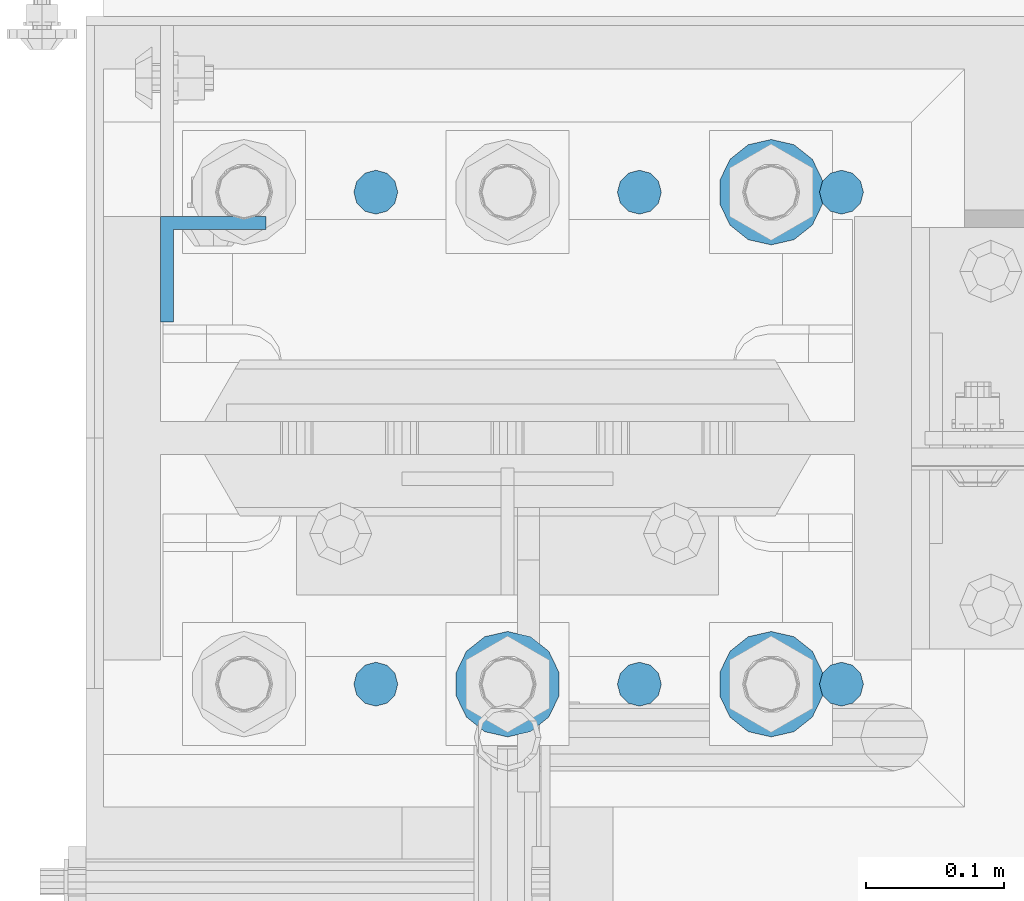
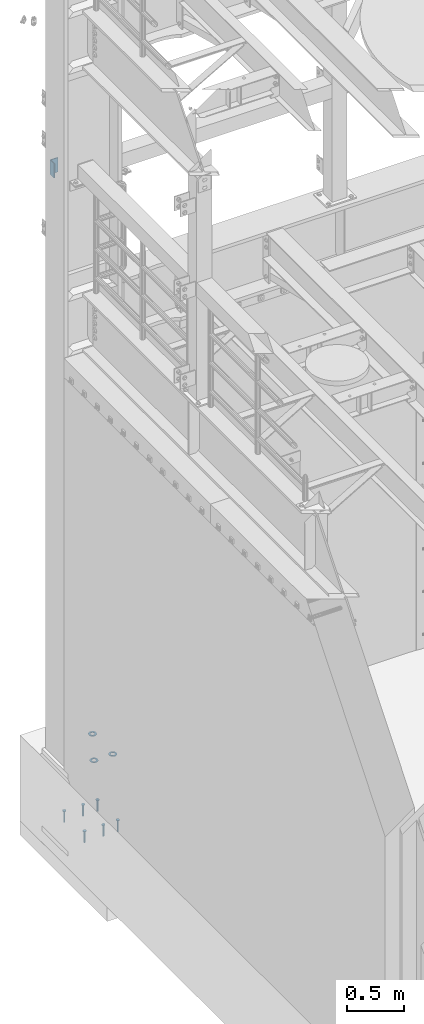
# One storey, part 854 of 1876: 10 columns, 2 elements without a shape of their own.
"""IFC2X3 building model written with IfcOpenShell, lengths in millimetres."""

from ifc_helpers import new_model, si_unit, frame, origin_with_axes, place, context, subcontext, project, spatial, faceted_brep, material, type_object, element, aggregate, save


model = new_model("IFC2X3")

# Units and contexts
model_context = context("Model", 3, precision=1e-05, world=origin_with_axes())
body_context = subcontext(model_context, "Body", "Model", "MODEL_VIEW")
ifc_project = project(units=[si_unit("LENGTHUNIT", "METRE", prefix="MILLI"), si_unit("AREAUNIT", "SQUARE_METRE"), si_unit("VOLUMEUNIT", "CUBIC_METRE"), si_unit("MASSUNIT", "GRAM", prefix="KILO"), si_unit("TIMEUNIT", "SECOND"), si_unit("PLANEANGLEUNIT", "RADIAN"), si_unit("SOLIDANGLEUNIT", "STERADIAN"), si_unit("THERMODYNAMICTEMPERATUREUNIT", "DEGREE_CELSIUS"), si_unit("LUMINOUSINTENSITYUNIT", "LUMEN")], contexts=[model_context])

# Site, building, storey
site_placement = place(None, origin_with_axes())
site = spatial("IfcSite", under=ifc_project, at=site_placement, CompositionType="ELEMENT")
building_placement = place(site_placement, origin_with_axes())
building = spatial("IfcBuilding", under=site, at=building_placement, Name="Undefined", CompositionType="ELEMENT")
storey_placement = place(building_placement, origin_with_axes())
storey = spatial("IfcBuildingStorey", under=building, at=storey_placement, Name="Undefined", CompositionType="ELEMENT", Elevation=0.0)

# Assembly, column
assembly_1_placement = place(storey_placement, origin_with_axes())
assembly_1 = element("IfcElementAssembly", 1, at=assembly_1_placement, inside=storey, Name="COLUMN", AssemblyPlace="NOTDEFINED", PredefinedType="RIGID_FRAME")
ifc_material_1 = material(Name="STEEL/A36")
column_type_1 = type_object("IfcColumnType", Name="L3X3X3/8", PredefinedType="NOTDEFINED")
column_1_placement = place(assembly_1_placement, frame((-212.725, 13838.2375, 6254.75), z_axis=(0.0, -1.0, 0.0), x_axis=(0.0, 0.0, 1.0)))
column_1 = element("IfcColumn", 2, at=column_1_placement, type_object=column_type_1, material=ifc_material_1, Name="ANGLE", ObjectType="L3X3X3/8", context=body_context, shape_type="Brep", body=[
    faceted_brep([(0.0, 38.1000000000004, -38.1), (0.0, 38.1000000000004, 38.1), (152.4, 38.1000000000004, 38.1), (152.4, 38.1000000000004, -38.1), (0.0, 28.5749999999998, 38.1), (152.4, 28.5749999999998, 38.1), (0.0, 28.5749999999998, -28.575), (152.4, 28.5749999999998, -28.575), (0.0, -38.1000000000004, -28.575), (152.4, -38.1000000000004, -28.575), (0.0, -38.1000000000004, -38.1), (152.4, -38.1000000000004, -38.1)], [[[0, 1, 2, 3]], [[1, 4, 5, 2]], [[4, 6, 7, 5]], [[6, 8, 9, 7]], [[8, 10, 11, 9]], [[10, 0, 3, 11]], [[5, 7, 9, 11, 3, 2]], [[10, 8, 6, 4, 1, 0]]]),
])
aggregate(assembly_1, [column_1])

# Assembly, columns
assembly_2_placement = place(storey_placement, origin_with_axes())
assembly_2 = element("IfcElementAssembly", 3, at=assembly_2_placement, inside=storey, Name="TEMPLATE", AssemblyPlace="NOTDEFINED", PredefinedType="RIGID_FRAME")
ifc_material_2 = material(Name="STEEL/F436")
column_type_2 = type_object("IfcColumnType", Name="1-1/2_WASHER", PredefinedType="NOTDEFINED")
column_2_placement = place(assembly_2_placement, frame((190.5, 13538.2, 109.5375), z_axis=(1.0, 0.0, 0.0), x_axis=(0.0, 0.0, -1.0)))
column_2 = element("IfcColumn", 4, at=column_2_placement, type_object=column_type_2, material=ifc_material_2, Name="WASHER", ObjectType="1-1/2_WASHER", context=body_context, shape_type="Brep", body=[
    faceted_brep([(0.0, -38.0999984741211, 0.0), (0.0, -34.3269124923136, -16.5309697983251), (4.7625, -34.3269124923136, -16.5309697983251), (4.7625, -38.0999984741211, 0.0), (0.0, -23.7549604994474, -29.787778289052), (4.7625, -23.7549604994474, -29.787778289052), (0.0, -8.4780472441962, -37.1447519665058), (4.7625, -8.4780472441962, -37.1447519665058), (0.0, 8.4780472441962, -37.1447519665058), (4.7625, 8.4780472441962, -37.1447519665058), (0.0, 23.7549604994474, -29.787778289052), (4.7625, 23.7549604994474, -29.787778289052), (0.0, 34.3269124923136, -16.5309697983251), (4.7625, 34.3269124923136, -16.5309697983251), (0.0, 38.0999984741211, 0.0), (4.7625, 38.0999984741211, 0.0), (0.0, 34.3269124923136, 16.5309697983251), (4.7625, 34.3269124923136, 16.5309697983251), (0.0, 23.7549604994474, 29.787778289052), (4.7625, 23.7549604994474, 29.787778289052), (0.0, 8.4780472441962, 37.1447519665058), (4.7625, 8.4780472441962, 37.1447519665058), (0.0, -8.4780472441962, 37.1447519665058), (4.7625, -8.4780472441962, 37.1447519665058), (0.0, -23.7549604994474, 29.787778289052), (4.7625, -23.7549604994474, 29.787778289052), (0.0, -34.3269124923136, 16.5309697983251), (4.7625, -34.3269124923136, 16.5309697983251), (0.0, 0.0, 20.6399993896484), (0.0, 8.95536011056538, 18.5959968835978), (4.7625, 8.95536011056538, 18.595996883598), (4.7625, 0.0, 20.6399993896484), (0.0, 16.1370013209489, 12.8688291298158), (4.7625, 16.1370013209489, 12.8688291298162), (0.0, 20.1225115123834, 4.59283194104228), (4.7625, 20.1225115123834, 4.59283194104222), (0.0, 20.1225115123834, -4.59283194104228), (4.7625, 20.1225115123834, -4.59283194104242), (0.0, 16.1370013209489, -12.8688291298167), (4.7625, 16.1370013209489, -12.8688291298163), (0.0, 8.95536011056538, -18.5959968835978), (4.7625, 8.95536011056538, -18.5959968835982), (0.0, 0.0, -20.6399993896484), (4.7625, 0.0, -20.6399993896484), (0.0, -8.95536011056538, -18.5959968835978), (4.7625, -8.95536011056538, -18.595996883598), (0.0, -16.1370013209489, -12.8688291298158), (4.7625, -16.1370013209489, -12.8688291298162), (0.0, -20.1225115123834, -4.59283194104228), (4.7625, -20.1225115123834, -4.59283194104222), (0.0, -20.1225115123834, 4.59283194104228), (4.7625, -20.1225115123834, 4.59283194104242), (0.0, -16.1370013209489, 12.8688291298167), (4.7625, -16.1370013209489, 12.8688291298163), (0.0, -8.95536011056538, 18.5959968835978), (4.7625, -8.95536011056538, 18.5959968835982)], [[[0, 1, 2, 3]], [[1, 4, 5, 2]], [[4, 6, 7, 5]], [[6, 8, 9, 7]], [[8, 10, 11, 9]], [[10, 12, 13, 11]], [[12, 14, 15, 13]], [[14, 16, 17, 15]], [[16, 18, 19, 17]], [[18, 20, 21, 19]], [[20, 22, 23, 21]], [[22, 24, 25, 23]], [[24, 26, 27, 25]], [[26, 0, 3, 27]], [[28, 29, 30, 31]], [[29, 32, 33, 30]], [[32, 34, 35, 33]], [[34, 36, 37, 35]], [[36, 38, 39, 37]], [[38, 40, 41, 39]], [[40, 42, 43, 41]], [[42, 44, 45, 43]], [[44, 46, 47, 45]], [[46, 48, 49, 47]], [[48, 50, 51, 49]], [[50, 52, 53, 51]], [[52, 54, 55, 53]], [[54, 28, 31, 55]], [[5, 7, 9, 11, 13, 15, 17, 19, 21, 23, 25, 27, 3, 2], [33, 35, 37, 39, 41, 43, 45, 47, 49, 51, 53, 55, 31, 30]], [[26, 24, 22, 20, 18, 16, 14, 12, 10, 8, 6, 4, 1, 0], [54, 52, 50, 48, 46, 44, 42, 40, 38, 36, 34, 32, 29, 28]]]),
])
column_3_placement = place(assembly_2_placement, frame((190.5, 13893.8, 109.5375), z_axis=(-1.0, 0.0, 0.0), x_axis=(0.0, 0.0, -1.0)))
column_3 = element("IfcColumn", 5, at=column_3_placement, type_object=column_type_2, material=ifc_material_2, Name="WASHER", ObjectType="1-1/2_WASHER", context=body_context, shape_type="Brep", body=[
    faceted_brep([(0.0, -38.0999984741211, 0.0), (0.0, -34.3269124923136, -16.5309697983251), (4.7625, -34.3269124923136, -16.5309697983251), (4.7625, -38.0999984741211, 0.0), (0.0, -23.7549604994474, -29.787778289052), (4.7625, -23.7549604994474, -29.787778289052), (0.0, -8.4780472441962, -37.1447519665058), (4.7625, -8.4780472441962, -37.1447519665058), (0.0, 8.4780472441962, -37.1447519665058), (4.7625, 8.4780472441962, -37.1447519665058), (0.0, 23.7549604994474, -29.787778289052), (4.7625, 23.7549604994474, -29.787778289052), (0.0, 34.3269124923136, -16.5309697983251), (4.7625, 34.3269124923136, -16.5309697983251), (0.0, 38.0999984741211, 0.0), (4.7625, 38.0999984741211, 0.0), (0.0, 34.3269124923136, 16.5309697983251), (4.7625, 34.3269124923136, 16.5309697983251), (0.0, 23.7549604994474, 29.787778289052), (4.7625, 23.7549604994474, 29.787778289052), (0.0, 8.4780472441962, 37.1447519665058), (4.7625, 8.4780472441962, 37.1447519665058), (0.0, -8.4780472441962, 37.1447519665058), (4.7625, -8.4780472441962, 37.1447519665058), (0.0, -23.7549604994474, 29.787778289052), (4.7625, -23.7549604994474, 29.787778289052), (0.0, -34.3269124923136, 16.5309697983251), (4.7625, -34.3269124923136, 16.5309697983251), (0.0, 0.0, 20.6399993896484), (0.0, 8.95536011056538, 18.5959968835978), (4.7625, 8.95536011056538, 18.595996883598), (4.7625, 0.0, 20.6399993896484), (0.0, 16.1370013209489, 12.8688291298158), (4.7625, 16.1370013209489, 12.8688291298162), (0.0, 20.1225115123834, 4.59283194104228), (4.7625, 20.1225115123834, 4.59283194104222), (0.0, 20.1225115123834, -4.59283194104228), (4.7625, 20.1225115123834, -4.59283194104242), (0.0, 16.1370013209489, -12.8688291298167), (4.7625, 16.1370013209489, -12.8688291298163), (0.0, 8.95536011056538, -18.5959968835978), (4.7625, 8.95536011056538, -18.5959968835982), (0.0, 0.0, -20.6399993896484), (4.7625, 0.0, -20.6399993896484), (0.0, -8.95536011056538, -18.5959968835978), (4.7625, -8.95536011056538, -18.595996883598), (0.0, -16.1370013209489, -12.8688291298158), (4.7625, -16.1370013209489, -12.8688291298162), (0.0, -20.1225115123834, -4.59283194104228), (4.7625, -20.1225115123834, -4.59283194104222), (0.0, -20.1225115123834, 4.59283194104228), (4.7625, -20.1225115123834, 4.59283194104242), (0.0, -16.1370013209489, 12.8688291298167), (4.7625, -16.1370013209489, 12.8688291298163), (0.0, -8.95536011056538, 18.5959968835978), (4.7625, -8.95536011056538, 18.5959968835982)], [[[0, 1, 2, 3]], [[1, 4, 5, 2]], [[4, 6, 7, 5]], [[6, 8, 9, 7]], [[8, 10, 11, 9]], [[10, 12, 13, 11]], [[12, 14, 15, 13]], [[14, 16, 17, 15]], [[16, 18, 19, 17]], [[18, 20, 21, 19]], [[20, 22, 23, 21]], [[22, 24, 25, 23]], [[24, 26, 27, 25]], [[26, 0, 3, 27]], [[28, 29, 30, 31]], [[29, 32, 33, 30]], [[32, 34, 35, 33]], [[34, 36, 37, 35]], [[36, 38, 39, 37]], [[38, 40, 41, 39]], [[40, 42, 43, 41]], [[42, 44, 45, 43]], [[44, 46, 47, 45]], [[46, 48, 49, 47]], [[48, 50, 51, 49]], [[50, 52, 53, 51]], [[52, 54, 55, 53]], [[54, 28, 31, 55]], [[5, 7, 9, 11, 13, 15, 17, 19, 21, 23, 25, 27, 3, 2], [33, 35, 37, 39, 41, 43, 45, 47, 49, 51, 53, 55, 31, 30]], [[26, 24, 22, 20, 18, 16, 14, 12, 10, 8, 6, 4, 1, 0], [54, 52, 50, 48, 46, 44, 42, 40, 38, 36, 34, 32, 29, 28]]]),
])
column_4_placement = place(assembly_2_placement, frame((-2.8421709430404e-14, 13538.2, 109.5375), z_axis=(1.0, 0.0, 0.0), x_axis=(0.0, 0.0, -1.0)))
column_4 = element("IfcColumn", 6, at=column_4_placement, type_object=column_type_2, material=ifc_material_2, Name="WASHER", ObjectType="1-1/2_WASHER", context=body_context, shape_type="Brep", body=[
    faceted_brep([(0.0, -38.0999984741211, 0.0), (0.0, -34.3269124923136, -16.5309697983251), (4.7625, -34.3269124923136, -16.5309697983251), (4.7625, -38.0999984741211, 0.0), (0.0, -23.7549604994474, -29.787778289052), (4.7625, -23.7549604994474, -29.787778289052), (0.0, -8.4780472441962, -37.1447519665058), (4.7625, -8.4780472441962, -37.1447519665058), (0.0, 8.4780472441962, -37.1447519665058), (4.7625, 8.4780472441962, -37.1447519665058), (0.0, 23.7549604994474, -29.787778289052), (4.7625, 23.7549604994474, -29.787778289052), (0.0, 34.3269124923136, -16.5309697983251), (4.7625, 34.3269124923136, -16.5309697983251), (0.0, 38.0999984741211, 0.0), (4.7625, 38.0999984741211, 0.0), (0.0, 34.3269124923136, 16.5309697983251), (4.7625, 34.3269124923136, 16.5309697983251), (0.0, 23.7549604994474, 29.787778289052), (4.7625, 23.7549604994474, 29.787778289052), (0.0, 8.4780472441962, 37.1447519665058), (4.7625, 8.4780472441962, 37.1447519665058), (0.0, -8.4780472441962, 37.1447519665058), (4.7625, -8.4780472441962, 37.1447519665058), (0.0, -23.7549604994474, 29.787778289052), (4.7625, -23.7549604994474, 29.787778289052), (0.0, -34.3269124923136, 16.5309697983251), (4.7625, -34.3269124923136, 16.5309697983251), (0.0, 0.0, 20.6399993896484), (0.0, 8.95536011056538, 18.5959968835978), (4.7625, 8.95536011056538, 18.595996883598), (4.7625, 0.0, 20.6399993896484), (0.0, 16.1370013209489, 12.8688291298158), (4.7625, 16.1370013209489, 12.8688291298162), (0.0, 20.1225115123834, 4.59283194104228), (4.7625, 20.1225115123834, 4.59283194104222), (0.0, 20.1225115123834, -4.59283194104228), (4.7625, 20.1225115123834, -4.59283194104242), (0.0, 16.1370013209489, -12.8688291298167), (4.7625, 16.1370013209489, -12.8688291298163), (0.0, 8.95536011056538, -18.5959968835978), (4.7625, 8.95536011056538, -18.5959968835982), (0.0, 0.0, -20.6399993896484), (4.7625, 0.0, -20.6399993896484), (0.0, -8.95536011056538, -18.5959968835978), (4.7625, -8.95536011056538, -18.595996883598), (0.0, -16.1370013209489, -12.8688291298158), (4.7625, -16.1370013209489, -12.8688291298162), (0.0, -20.1225115123834, -4.59283194104228), (4.7625, -20.1225115123834, -4.59283194104222), (0.0, -20.1225115123834, 4.59283194104228), (4.7625, -20.1225115123834, 4.59283194104242), (0.0, -16.1370013209489, 12.8688291298167), (4.7625, -16.1370013209489, 12.8688291298163), (0.0, -8.95536011056538, 18.5959968835978), (4.7625, -8.95536011056538, 18.5959968835982)], [[[0, 1, 2, 3]], [[1, 4, 5, 2]], [[4, 6, 7, 5]], [[6, 8, 9, 7]], [[8, 10, 11, 9]], [[10, 12, 13, 11]], [[12, 14, 15, 13]], [[14, 16, 17, 15]], [[16, 18, 19, 17]], [[18, 20, 21, 19]], [[20, 22, 23, 21]], [[22, 24, 25, 23]], [[24, 26, 27, 25]], [[26, 0, 3, 27]], [[28, 29, 30, 31]], [[29, 32, 33, 30]], [[32, 34, 35, 33]], [[34, 36, 37, 35]], [[36, 38, 39, 37]], [[38, 40, 41, 39]], [[40, 42, 43, 41]], [[42, 44, 45, 43]], [[44, 46, 47, 45]], [[46, 48, 49, 47]], [[48, 50, 51, 49]], [[50, 52, 53, 51]], [[52, 54, 55, 53]], [[54, 28, 31, 55]], [[5, 7, 9, 11, 13, 15, 17, 19, 21, 23, 25, 27, 3, 2], [33, 35, 37, 39, 41, 43, 45, 47, 49, 51, 53, 55, 31, 30]], [[26, 24, 22, 20, 18, 16, 14, 12, 10, 8, 6, 4, 1, 0], [54, 52, 50, 48, 46, 44, 42, 40, 38, 36, 34, 32, 29, 28]]]),
])
ifc_material_3 = material(Name="STEEL/A108")
column_type_3 = type_object("IfcColumnType", Name="5/8-DIA_HEADED ANCHOR STUD", PredefinedType="NOTDEFINED")
column_5_placement = place(assembly_2_placement, frame((241.299998474121, 13893.8, -736.6), z_axis=(1.0, 0.0, 0.0), x_axis=(0.0, 0.0, 1.0)))
column_5 = element("IfcColumn", 7, at=column_5_placement, type_object=column_type_3, material=ifc_material_3, Name="HEADED ANCHOR STUD", ObjectType="5/8-DIA_HEADED ANCHOR STUD", context=body_context, shape_type="Brep", body=[
    faceted_brep([(0.0, -7.94000005722046, 0.0), (0.0, -6.86999988555908, -3.97000002861023), (116.84, -6.86999988555908, -3.97000002861023), (116.84, -7.94000005722046, 0.0), (0.0, -3.97000002861023, -6.86999988555908), (116.84, -3.97000002861023, -6.86999988555908), (0.0, 0.0, -7.94000005722046), (116.84, 0.0, -7.94000005722046), (0.0, 3.97000002861023, -6.86999988555908), (116.84, 3.97000002861023, -6.86999988555908), (0.0, 6.86999988555908, -3.97000002861023), (116.84, 6.86999988555908, -3.97000002861023), (0.0, 7.94000005722046, 0.0), (116.84, 7.94000005722046, 0.0), (0.0, 6.86999988555908, 3.97000002861023), (116.84, 6.86999988555908, 3.97000002861023), (0.0, 3.97000002861023, 6.86999988555908), (116.84, 3.97000002861023, 6.86999988555908), (0.0, 0.0, 7.94000005722046), (116.84, 0.0, 7.94000005722046), (0.0, -3.97000002861023, 6.86999988555908), (116.84, -3.97000002861023, 6.86999988555908), (0.0, -6.86999988555908, 3.97000002861023), (116.84, -6.86999988555908, 3.97000002861023), (118.11, -13.75, -7.94000005722046), (118.11, -15.8800001144409, 0.0), (118.11, -7.94000005722046, -13.75), (118.11, 0.0, -15.8800001144409), (118.11, 7.94000005722046, -13.75), (118.11, 13.75, -7.94000005722046), (118.11, 15.8800001144409, 0.0), (118.11, 13.75, 7.94000005722046), (118.11, 7.94000005722046, 13.75), (118.11, 0.0, 15.8800001144409), (118.11, -7.94000005722046, 13.75), (118.11, -13.75, 7.94000005722046), (127.0, -13.75, -7.94000005722046), (127.0, -15.8800001144409, 0.0), (127.0, -7.94000005722046, -13.75), (127.0, 0.0, -15.8800001144409), (127.0, 7.94000005722046, -13.75), (127.0, 13.75, -7.94000005722046), (127.0, 15.8800001144409, 0.0), (127.0, 13.75, 7.94000005722046), (127.0, 7.94000005722046, 13.75), (127.0, 0.0, 15.8800001144409), (127.0, -7.94000005722046, 13.75), (127.0, -13.75, 7.94000005722046)], [[[0, 1, 2, 3]], [[1, 4, 5, 2]], [[4, 6, 7, 5]], [[6, 8, 9, 7]], [[8, 10, 11, 9]], [[10, 12, 13, 11]], [[12, 14, 15, 13]], [[14, 16, 17, 15]], [[16, 18, 19, 17]], [[18, 20, 21, 19]], [[20, 22, 23, 21]], [[22, 0, 3, 23]], [[22, 20, 18, 16, 14, 12, 10, 8, 6, 4, 1, 0]], [[3, 2, 24, 25]], [[2, 5, 26, 24]], [[5, 7, 27, 26]], [[7, 9, 28, 27]], [[9, 11, 29, 28]], [[11, 13, 30, 29]], [[13, 15, 31, 30]], [[15, 17, 32, 31]], [[17, 19, 33, 32]], [[19, 21, 34, 33]], [[21, 23, 35, 34]], [[23, 3, 25, 35]], [[25, 24, 36, 37]], [[24, 26, 38, 36]], [[26, 27, 39, 38]], [[27, 28, 40, 39]], [[28, 29, 41, 40]], [[29, 30, 42, 41]], [[30, 31, 43, 42]], [[31, 32, 44, 43]], [[32, 33, 45, 44]], [[33, 34, 46, 45]], [[34, 35, 47, 46]], [[35, 25, 37, 47]], [[38, 39, 40, 41, 42, 43, 44, 45, 46, 47, 37, 36]]]),
])
column_6_placement = place(assembly_2_placement, frame((241.299998474121, 13538.2, -736.6), z_axis=(1.0, 0.0, 0.0), x_axis=(0.0, 0.0, 1.0)))
column_6 = element("IfcColumn", 8, at=column_6_placement, type_object=column_type_3, material=ifc_material_3, Name="HEADED ANCHOR STUD", ObjectType="5/8-DIA_HEADED ANCHOR STUD", context=body_context, shape_type="Brep", body=[
    faceted_brep([(0.0, -7.94000005722046, 0.0), (0.0, -6.86999988555908, -3.97000002861023), (116.84, -6.86999988555908, -3.97000002861023), (116.84, -7.94000005722046, 0.0), (0.0, -3.97000002861023, -6.86999988555908), (116.84, -3.97000002861023, -6.86999988555908), (0.0, 0.0, -7.94000005722046), (116.84, 0.0, -7.94000005722046), (0.0, 3.97000002861023, -6.86999988555908), (116.84, 3.97000002861023, -6.86999988555908), (0.0, 6.86999988555908, -3.97000002861023), (116.84, 6.86999988555908, -3.97000002861023), (0.0, 7.94000005722046, 0.0), (116.84, 7.94000005722046, 0.0), (0.0, 6.86999988555908, 3.97000002861023), (116.84, 6.86999988555908, 3.97000002861023), (0.0, 3.97000002861023, 6.86999988555908), (116.84, 3.97000002861023, 6.86999988555908), (0.0, 0.0, 7.94000005722046), (116.84, 0.0, 7.94000005722046), (0.0, -3.97000002861023, 6.86999988555908), (116.84, -3.97000002861023, 6.86999988555908), (0.0, -6.86999988555908, 3.97000002861023), (116.84, -6.86999988555908, 3.97000002861023), (118.11, -13.75, -7.94000005722046), (118.11, -15.8800001144409, 0.0), (118.11, -7.94000005722046, -13.75), (118.11, 0.0, -15.8800001144409), (118.11, 7.94000005722046, -13.75), (118.11, 13.75, -7.94000005722046), (118.11, 15.8800001144409, 0.0), (118.11, 13.75, 7.94000005722046), (118.11, 7.94000005722046, 13.75), (118.11, 0.0, 15.8800001144409), (118.11, -7.94000005722046, 13.75), (118.11, -13.75, 7.94000005722046), (127.0, -13.75, -7.94000005722046), (127.0, -15.8800001144409, 0.0), (127.0, -7.94000005722046, -13.75), (127.0, 0.0, -15.8800001144409), (127.0, 7.94000005722046, -13.75), (127.0, 13.75, -7.94000005722046), (127.0, 15.8800001144409, 0.0), (127.0, 13.75, 7.94000005722046), (127.0, 7.94000005722046, 13.75), (127.0, 0.0, 15.8800001144409), (127.0, -7.94000005722046, 13.75), (127.0, -13.75, 7.94000005722046)], [[[0, 1, 2, 3]], [[1, 4, 5, 2]], [[4, 6, 7, 5]], [[6, 8, 9, 7]], [[8, 10, 11, 9]], [[10, 12, 13, 11]], [[12, 14, 15, 13]], [[14, 16, 17, 15]], [[16, 18, 19, 17]], [[18, 20, 21, 19]], [[20, 22, 23, 21]], [[22, 0, 3, 23]], [[22, 20, 18, 16, 14, 12, 10, 8, 6, 4, 1, 0]], [[3, 2, 24, 25]], [[2, 5, 26, 24]], [[5, 7, 27, 26]], [[7, 9, 28, 27]], [[9, 11, 29, 28]], [[11, 13, 30, 29]], [[13, 15, 31, 30]], [[15, 17, 32, 31]], [[17, 19, 33, 32]], [[19, 21, 34, 33]], [[21, 23, 35, 34]], [[23, 3, 25, 35]], [[25, 24, 36, 37]], [[24, 26, 38, 36]], [[26, 27, 39, 38]], [[27, 28, 40, 39]], [[28, 29, 41, 40]], [[29, 30, 42, 41]], [[30, 31, 43, 42]], [[31, 32, 44, 43]], [[32, 33, 45, 44]], [[33, 34, 46, 45]], [[34, 35, 47, 46]], [[35, 25, 37, 47]], [[38, 39, 40, 41, 42, 43, 44, 45, 46, 47, 37, 36]]]),
])
column_7_placement = place(assembly_2_placement, frame((-95.2500000000009, 13893.8, -736.6), z_axis=(1.0, 0.0, 0.0), x_axis=(0.0, 0.0, 1.0)))
column_7 = element("IfcColumn", 9, at=column_7_placement, type_object=column_type_3, material=ifc_material_3, Name="HEADED ANCHOR STUD", ObjectType="5/8-DIA_HEADED ANCHOR STUD", context=body_context, shape_type="Brep", body=[
    faceted_brep([(0.0, -7.94000005722046, 0.0), (0.0, -6.86999988555908, -3.97000002861023), (116.84, -6.86999988555908, -3.97000002861023), (116.84, -7.94000005722046, 0.0), (0.0, -3.97000002861023, -6.86999988555908), (116.84, -3.97000002861023, -6.86999988555908), (0.0, 0.0, -7.94000005722046), (116.84, 0.0, -7.94000005722046), (0.0, 3.97000002861023, -6.86999988555908), (116.84, 3.97000002861023, -6.86999988555908), (0.0, 6.86999988555908, -3.97000002861023), (116.84, 6.86999988555908, -3.97000002861023), (0.0, 7.94000005722046, 0.0), (116.84, 7.94000005722046, 0.0), (0.0, 6.86999988555908, 3.97000002861023), (116.84, 6.86999988555908, 3.97000002861023), (0.0, 3.97000002861023, 6.86999988555908), (116.84, 3.97000002861023, 6.86999988555908), (0.0, 0.0, 7.94000005722046), (116.84, 0.0, 7.94000005722046), (0.0, -3.97000002861023, 6.86999988555908), (116.84, -3.97000002861023, 6.86999988555908), (0.0, -6.86999988555908, 3.97000002861023), (116.84, -6.86999988555908, 3.97000002861023), (118.11, -13.75, -7.94000005722046), (118.11, -15.8800001144409, 0.0), (118.11, -7.94000005722046, -13.75), (118.11, 0.0, -15.8800001144409), (118.11, 7.94000005722046, -13.75), (118.11, 13.75, -7.94000005722046), (118.11, 15.8800001144409, 0.0), (118.11, 13.75, 7.94000005722046), (118.11, 7.94000005722046, 13.75), (118.11, 0.0, 15.8800001144409), (118.11, -7.94000005722046, 13.75), (118.11, -13.75, 7.94000005722046), (127.0, -13.75, -7.94000005722046), (127.0, -15.8800001144409, 0.0), (127.0, -7.94000005722046, -13.75), (127.0, 0.0, -15.8800001144409), (127.0, 7.94000005722046, -13.75), (127.0, 13.75, -7.94000005722046), (127.0, 15.8800001144409, 0.0), (127.0, 13.75, 7.94000005722046), (127.0, 7.94000005722046, 13.75), (127.0, 0.0, 15.8800001144409), (127.0, -7.94000005722046, 13.75), (127.0, -13.75, 7.94000005722046)], [[[0, 1, 2, 3]], [[1, 4, 5, 2]], [[4, 6, 7, 5]], [[6, 8, 9, 7]], [[8, 10, 11, 9]], [[10, 12, 13, 11]], [[12, 14, 15, 13]], [[14, 16, 17, 15]], [[16, 18, 19, 17]], [[18, 20, 21, 19]], [[20, 22, 23, 21]], [[22, 0, 3, 23]], [[22, 20, 18, 16, 14, 12, 10, 8, 6, 4, 1, 0]], [[3, 2, 24, 25]], [[2, 5, 26, 24]], [[5, 7, 27, 26]], [[7, 9, 28, 27]], [[9, 11, 29, 28]], [[11, 13, 30, 29]], [[13, 15, 31, 30]], [[15, 17, 32, 31]], [[17, 19, 33, 32]], [[19, 21, 34, 33]], [[21, 23, 35, 34]], [[23, 3, 25, 35]], [[25, 24, 36, 37]], [[24, 26, 38, 36]], [[26, 27, 39, 38]], [[27, 28, 40, 39]], [[28, 29, 41, 40]], [[29, 30, 42, 41]], [[30, 31, 43, 42]], [[31, 32, 44, 43]], [[32, 33, 45, 44]], [[33, 34, 46, 45]], [[34, 35, 47, 46]], [[35, 25, 37, 47]], [[38, 39, 40, 41, 42, 43, 44, 45, 46, 47, 37, 36]]]),
])
column_8_placement = place(assembly_2_placement, frame((-95.2500000000009, 13538.2, -736.6), z_axis=(1.0, 0.0, 0.0), x_axis=(0.0, 0.0, 1.0)))
column_8 = element("IfcColumn", 10, at=column_8_placement, type_object=column_type_3, material=ifc_material_3, Name="HEADED ANCHOR STUD", ObjectType="5/8-DIA_HEADED ANCHOR STUD", context=body_context, shape_type="Brep", body=[
    faceted_brep([(0.0, -7.94000005722046, 0.0), (0.0, -6.86999988555908, -3.97000002861023), (116.84, -6.86999988555908, -3.97000002861023), (116.84, -7.94000005722046, 0.0), (0.0, -3.97000002861023, -6.86999988555908), (116.84, -3.97000002861023, -6.86999988555908), (0.0, 0.0, -7.94000005722046), (116.84, 0.0, -7.94000005722046), (0.0, 3.97000002861023, -6.86999988555908), (116.84, 3.97000002861023, -6.86999988555908), (0.0, 6.86999988555908, -3.97000002861023), (116.84, 6.86999988555908, -3.97000002861023), (0.0, 7.94000005722046, 0.0), (116.84, 7.94000005722046, 0.0), (0.0, 6.86999988555908, 3.97000002861023), (116.84, 6.86999988555908, 3.97000002861023), (0.0, 3.97000002861023, 6.86999988555908), (116.84, 3.97000002861023, 6.86999988555908), (0.0, 0.0, 7.94000005722046), (116.84, 0.0, 7.94000005722046), (0.0, -3.97000002861023, 6.86999988555908), (116.84, -3.97000002861023, 6.86999988555908), (0.0, -6.86999988555908, 3.97000002861023), (116.84, -6.86999988555908, 3.97000002861023), (118.11, -13.75, -7.94000005722046), (118.11, -15.8800001144409, 0.0), (118.11, -7.94000005722046, -13.75), (118.11, 0.0, -15.8800001144409), (118.11, 7.94000005722046, -13.75), (118.11, 13.75, -7.94000005722046), (118.11, 15.8800001144409, 0.0), (118.11, 13.75, 7.94000005722046), (118.11, 7.94000005722046, 13.75), (118.11, 0.0, 15.8800001144409), (118.11, -7.94000005722046, 13.75), (118.11, -13.75, 7.94000005722046), (127.0, -13.75, -7.94000005722046), (127.0, -15.8800001144409, 0.0), (127.0, -7.94000005722046, -13.75), (127.0, 0.0, -15.8800001144409), (127.0, 7.94000005722046, -13.75), (127.0, 13.75, -7.94000005722046), (127.0, 15.8800001144409, 0.0), (127.0, 13.75, 7.94000005722046), (127.0, 7.94000005722046, 13.75), (127.0, 0.0, 15.8800001144409), (127.0, -7.94000005722046, 13.75), (127.0, -13.75, 7.94000005722046)], [[[0, 1, 2, 3]], [[1, 4, 5, 2]], [[4, 6, 7, 5]], [[6, 8, 9, 7]], [[8, 10, 11, 9]], [[10, 12, 13, 11]], [[12, 14, 15, 13]], [[14, 16, 17, 15]], [[16, 18, 19, 17]], [[18, 20, 21, 19]], [[20, 22, 23, 21]], [[22, 0, 3, 23]], [[22, 20, 18, 16, 14, 12, 10, 8, 6, 4, 1, 0]], [[3, 2, 24, 25]], [[2, 5, 26, 24]], [[5, 7, 27, 26]], [[7, 9, 28, 27]], [[9, 11, 29, 28]], [[11, 13, 30, 29]], [[13, 15, 31, 30]], [[15, 17, 32, 31]], [[17, 19, 33, 32]], [[19, 21, 34, 33]], [[21, 23, 35, 34]], [[23, 3, 25, 35]], [[25, 24, 36, 37]], [[24, 26, 38, 36]], [[26, 27, 39, 38]], [[27, 28, 40, 39]], [[28, 29, 41, 40]], [[29, 30, 42, 41]], [[30, 31, 43, 42]], [[31, 32, 44, 43]], [[32, 33, 45, 44]], [[33, 34, 46, 45]], [[34, 35, 47, 46]], [[35, 25, 37, 47]], [[38, 39, 40, 41, 42, 43, 44, 45, 46, 47, 37, 36]]]),
])
column_9_placement = place(assembly_2_placement, frame((95.25, 13893.8, -736.6), z_axis=(1.0, 0.0, 0.0), x_axis=(0.0, 0.0, 1.0)))
column_9 = element("IfcColumn", 11, at=column_9_placement, type_object=column_type_3, material=ifc_material_3, Name="HEADED ANCHOR STUD", ObjectType="5/8-DIA_HEADED ANCHOR STUD", context=body_context, shape_type="Brep", body=[
    faceted_brep([(0.0, -7.94000005722046, 0.0), (0.0, -6.86999988555908, -3.97000002861023), (116.84, -6.86999988555908, -3.97000002861023), (116.84, -7.94000005722046, 0.0), (0.0, -3.97000002861023, -6.86999988555908), (116.84, -3.97000002861023, -6.86999988555908), (0.0, 0.0, -7.94000005722046), (116.84, 0.0, -7.94000005722046), (0.0, 3.97000002861023, -6.86999988555908), (116.84, 3.97000002861023, -6.86999988555908), (0.0, 6.86999988555908, -3.97000002861023), (116.84, 6.86999988555908, -3.97000002861023), (0.0, 7.94000005722046, 0.0), (116.84, 7.94000005722046, 0.0), (0.0, 6.86999988555908, 3.97000002861023), (116.84, 6.86999988555908, 3.97000002861023), (0.0, 3.97000002861023, 6.86999988555908), (116.84, 3.97000002861023, 6.86999988555908), (0.0, 0.0, 7.94000005722046), (116.84, 0.0, 7.94000005722046), (0.0, -3.97000002861023, 6.86999988555908), (116.84, -3.97000002861023, 6.86999988555908), (0.0, -6.86999988555908, 3.97000002861023), (116.84, -6.86999988555908, 3.97000002861023), (118.11, -13.75, -7.94000005722046), (118.11, -15.8800001144409, 0.0), (118.11, -7.94000005722046, -13.75), (118.11, 0.0, -15.8800001144409), (118.11, 7.94000005722046, -13.75), (118.11, 13.75, -7.94000005722046), (118.11, 15.8800001144409, 0.0), (118.11, 13.75, 7.94000005722046), (118.11, 7.94000005722046, 13.75), (118.11, 0.0, 15.8800001144409), (118.11, -7.94000005722046, 13.75), (118.11, -13.75, 7.94000005722046), (127.0, -13.75, -7.94000005722046), (127.0, -15.8800001144409, 0.0), (127.0, -7.94000005722046, -13.75), (127.0, 0.0, -15.8800001144409), (127.0, 7.94000005722046, -13.75), (127.0, 13.75, -7.94000005722046), (127.0, 15.8800001144409, 0.0), (127.0, 13.75, 7.94000005722046), (127.0, 7.94000005722046, 13.75), (127.0, 0.0, 15.8800001144409), (127.0, -7.94000005722046, 13.75), (127.0, -13.75, 7.94000005722046)], [[[0, 1, 2, 3]], [[1, 4, 5, 2]], [[4, 6, 7, 5]], [[6, 8, 9, 7]], [[8, 10, 11, 9]], [[10, 12, 13, 11]], [[12, 14, 15, 13]], [[14, 16, 17, 15]], [[16, 18, 19, 17]], [[18, 20, 21, 19]], [[20, 22, 23, 21]], [[22, 0, 3, 23]], [[22, 20, 18, 16, 14, 12, 10, 8, 6, 4, 1, 0]], [[3, 2, 24, 25]], [[2, 5, 26, 24]], [[5, 7, 27, 26]], [[7, 9, 28, 27]], [[9, 11, 29, 28]], [[11, 13, 30, 29]], [[13, 15, 31, 30]], [[15, 17, 32, 31]], [[17, 19, 33, 32]], [[19, 21, 34, 33]], [[21, 23, 35, 34]], [[23, 3, 25, 35]], [[25, 24, 36, 37]], [[24, 26, 38, 36]], [[26, 27, 39, 38]], [[27, 28, 40, 39]], [[28, 29, 41, 40]], [[29, 30, 42, 41]], [[30, 31, 43, 42]], [[31, 32, 44, 43]], [[32, 33, 45, 44]], [[33, 34, 46, 45]], [[34, 35, 47, 46]], [[35, 25, 37, 47]], [[38, 39, 40, 41, 42, 43, 44, 45, 46, 47, 37, 36]]]),
])
column_10_placement = place(assembly_2_placement, frame((95.25, 13538.2, -736.6), z_axis=(1.0, 0.0, 0.0), x_axis=(0.0, 0.0, 1.0)))
column_10 = element("IfcColumn", 12, at=column_10_placement, type_object=column_type_3, material=ifc_material_3, Name="HEADED ANCHOR STUD", ObjectType="5/8-DIA_HEADED ANCHOR STUD", context=body_context, shape_type="Brep", body=[
    faceted_brep([(0.0, -7.94000005722046, 0.0), (0.0, -6.86999988555908, -3.97000002861023), (116.84, -6.86999988555908, -3.97000002861023), (116.84, -7.94000005722046, 0.0), (0.0, -3.97000002861023, -6.86999988555908), (116.84, -3.97000002861023, -6.86999988555908), (0.0, 0.0, -7.94000005722046), (116.84, 0.0, -7.94000005722046), (0.0, 3.97000002861023, -6.86999988555908), (116.84, 3.97000002861023, -6.86999988555908), (0.0, 6.86999988555908, -3.97000002861023), (116.84, 6.86999988555908, -3.97000002861023), (0.0, 7.94000005722046, 0.0), (116.84, 7.94000005722046, 0.0), (0.0, 6.86999988555908, 3.97000002861023), (116.84, 6.86999988555908, 3.97000002861023), (0.0, 3.97000002861023, 6.86999988555908), (116.84, 3.97000002861023, 6.86999988555908), (0.0, 0.0, 7.94000005722046), (116.84, 0.0, 7.94000005722046), (0.0, -3.97000002861023, 6.86999988555908), (116.84, -3.97000002861023, 6.86999988555908), (0.0, -6.86999988555908, 3.97000002861023), (116.84, -6.86999988555908, 3.97000002861023), (118.11, -13.75, -7.94000005722046), (118.11, -15.8800001144409, 0.0), (118.11, -7.94000005722046, -13.75), (118.11, 0.0, -15.8800001144409), (118.11, 7.94000005722046, -13.75), (118.11, 13.75, -7.94000005722046), (118.11, 15.8800001144409, 0.0), (118.11, 13.75, 7.94000005722046), (118.11, 7.94000005722046, 13.75), (118.11, 0.0, 15.8800001144409), (118.11, -7.94000005722046, 13.75), (118.11, -13.75, 7.94000005722046), (127.0, -13.75, -7.94000005722046), (127.0, -15.8800001144409, 0.0), (127.0, -7.94000005722046, -13.75), (127.0, 0.0, -15.8800001144409), (127.0, 7.94000005722046, -13.75), (127.0, 13.75, -7.94000005722046), (127.0, 15.8800001144409, 0.0), (127.0, 13.75, 7.94000005722046), (127.0, 7.94000005722046, 13.75), (127.0, 0.0, 15.8800001144409), (127.0, -7.94000005722046, 13.75), (127.0, -13.75, 7.94000005722046)], [[[0, 1, 2, 3]], [[1, 4, 5, 2]], [[4, 6, 7, 5]], [[6, 8, 9, 7]], [[8, 10, 11, 9]], [[10, 12, 13, 11]], [[12, 14, 15, 13]], [[14, 16, 17, 15]], [[16, 18, 19, 17]], [[18, 20, 21, 19]], [[20, 22, 23, 21]], [[22, 0, 3, 23]], [[22, 20, 18, 16, 14, 12, 10, 8, 6, 4, 1, 0]], [[3, 2, 24, 25]], [[2, 5, 26, 24]], [[5, 7, 27, 26]], [[7, 9, 28, 27]], [[9, 11, 29, 28]], [[11, 13, 30, 29]], [[13, 15, 31, 30]], [[15, 17, 32, 31]], [[17, 19, 33, 32]], [[19, 21, 34, 33]], [[21, 23, 35, 34]], [[23, 3, 25, 35]], [[25, 24, 36, 37]], [[24, 26, 38, 36]], [[26, 27, 39, 38]], [[27, 28, 40, 39]], [[28, 29, 41, 40]], [[29, 30, 42, 41]], [[30, 31, 43, 42]], [[31, 32, 44, 43]], [[32, 33, 45, 44]], [[33, 34, 46, 45]], [[34, 35, 47, 46]], [[35, 25, 37, 47]], [[38, 39, 40, 41, 42, 43, 44, 45, 46, 47, 37, 36]]]),
])
aggregate(assembly_2, [column_5, column_6, column_7, column_8, column_9, column_10, column_2, column_3, column_4])

save(model, "model.ifc")
